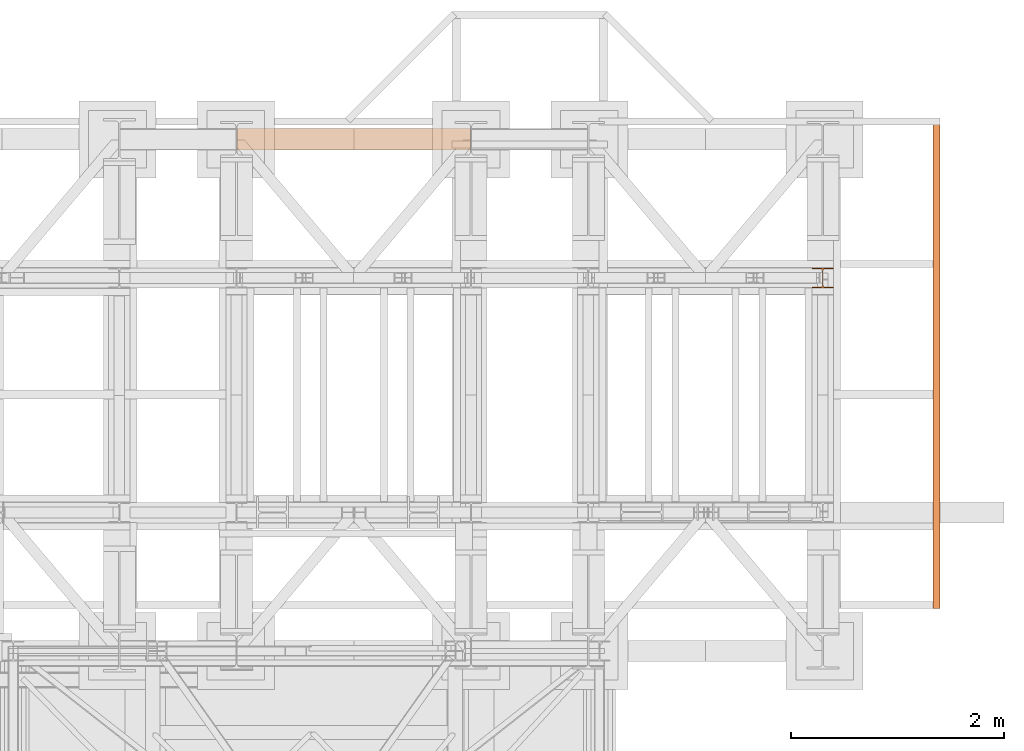
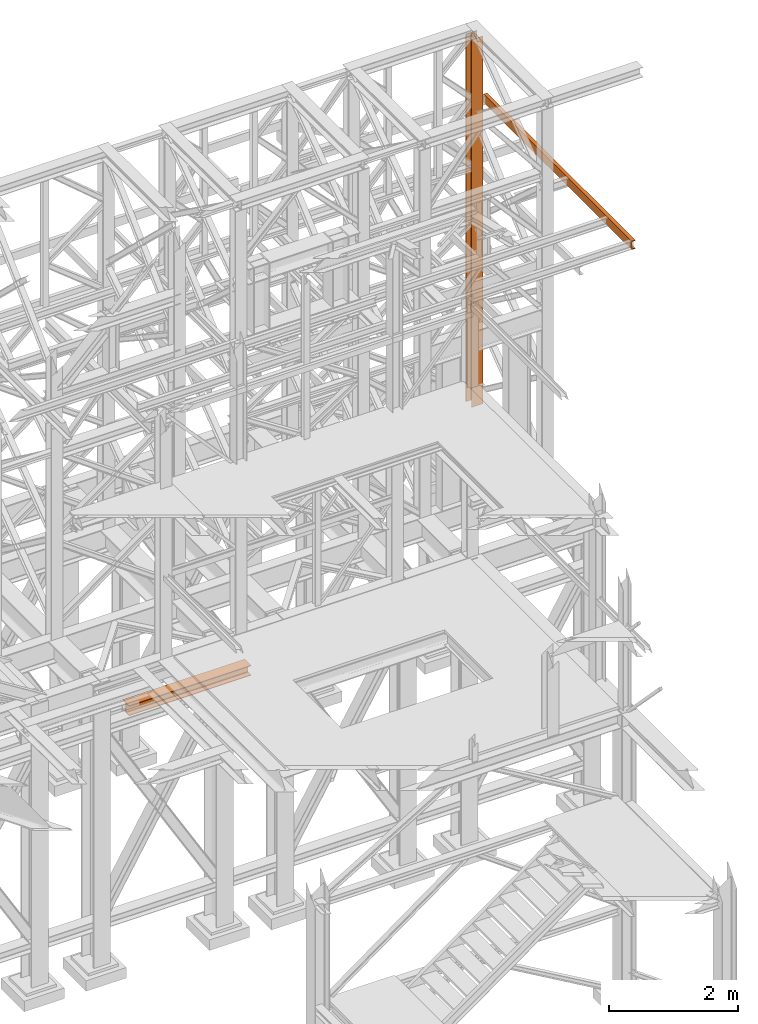
# One storey, part 190 of 208: 3 proxies.
"""IFC2X3 building model written with IfcOpenShell, lengths in millimetres."""

from ifc_helpers import new_model, entity, si_unit, converted_unit, frame, origin, origin_with_axes, place, context, subcontext, project, spatial, faceted_brep, element, save


model = new_model("IFC2X3")

# Units and contexts
model_context = context("Model", 3, precision=1e-05, world=origin())
plan_context = context("Plan", 3, precision=1e-05, world=origin())
body_context = subcontext(model_context, "Body", "Model", "MODEL_VIEW")
ifc_project = project(units=[si_unit("LENGTHUNIT", "METRE", prefix="MILLI"), converted_unit("PLANEANGLEUNIT", "DEGREE", entity("IfcPlaneAngleMeasure", 0.0174532925199433), si_unit("PLANEANGLEUNIT", "RADIAN"), dimensions=[0, 0, 0, 0, 0, 0, 0]), si_unit("AREAUNIT", "SQUARE_METRE"), si_unit("VOLUMEUNIT", "CUBIC_METRE")], contexts=[model_context, plan_context])

# Building, storey
building_placement = place(None, origin())
building = spatial("IfcBuilding", under=ifc_project, at=building_placement, CompositionType="COMPLEX")
storey_placement = place(building_placement, origin_with_axes())
storey = spatial("IfcBuildingStorey", under=building, at=storey_placement, Name="Geschoss", CompositionType="ELEMENT")

# Proxies
proxy_1_placement = place(storey_placement, frame((3299.254968580824, -12562.57439501764, 544.9900024165573), z_axis=(0.0, 0.0, 1.0), x_axis=(1.0, 0.0, 0.0)))
element("IfcBuildingElementProxy", 1, at=proxy_1_placement, inside=storey, context=body_context, shape_type="Brep", body=[
    faceted_brep([(2188.009999895689, 0.01000000000021828, 190.0100125169755), (2188.009999895689, 200.0100029802325, 190.0100125169755), (2188.009999895689, 200.0100029802325, 180.0100146031381), (2188.009999895689, 121.2600035762789, 180.0100071525575), (2188.009999895689, 111.9441915473344, 178.1454621052743), (2188.009999895689, 105.1245498640838, 171.3258190250398), (2188.009999895689, 103.2600015571716, 162.0100079274179), (2188.009999895689, 103.2600015571716, 28.00999713897716), (2188.009999895689, 105.1245498640838, 18.69418604135524), (2188.009999895689, 111.9441915473344, 11.87454296112071), (2188.009999895689, 121.2600035762789, 10.00999791383754), (2188.009999895689, 200.0100029802325, 10.00999791383754), (2188.009999895689, 200.0100029802325, 0.01000000000010459), (2188.009999895689, 0.01000000000021828, 0.01000000000010459), (2188.009999895689, 0.01000000000021828, 10.00999791383754), (2188.009999895689, 78.75999940395377, 10.00999791383754), (2188.009999895689, 88.07581143289826, 11.87454296112071), (2188.009999895689, 94.89545311614893, 18.69418604135524), (2188.009999895689, 96.76000142306111, 28.00999713897716), (2188.009999895689, 96.76000142306111, 162.0100079274179), (2188.009999895689, 94.89545311614893, 171.3258190250398), (2188.009999895689, 88.07581143289826, 178.1454621052743), (2188.009999895689, 78.75999940395377, 180.0100071525575), (2188.009999895689, 0.01000000000021828, 180.0100146031381), (2188.009999895689, 200.0100029802325, 190.0100125169755), (2188.009999895689, 0.01000000000021828, 190.0100125169755), (0.009999999999308784, 0.01000000000203727, 190.0100125169754), (0.009999999999308784, 200.0100029802343, 190.0100125169754), (2188.009999895689, 200.0100029802325, 180.0100146031381), (2188.009999895689, 200.0100029802325, 190.0100125169755), (0.009999999999308784, 200.0100029802343, 190.0100125169754), (0.009999999999308784, 200.0100029802343, 180.010014603138), (2188.009999895689, 121.2600035762789, 180.0100071525575), (2188.009999895689, 200.0100029802325, 180.0100146031381), (0.009999999999308784, 200.0100029802343, 180.010014603138), (0.009999999999308784, 121.2600035762807, 180.0100071525574), (2188.009999895689, 111.9441915473344, 178.1454621052743), (2188.009999895689, 121.2600035762789, 180.0100071525575), (0.009999999999308784, 121.2600035762807, 180.0100071525574), (0.009999999999308784, 111.9441915473362, 178.1454621052742), (2188.009999895689, 105.1245498640838, 171.3258190250398), (2188.009999895689, 111.9441915473344, 178.1454621052743), (0.009999999999308784, 111.9441915473362, 178.1454621052742), (0.009999999999308784, 105.1245498640856, 171.3258190250397), (2188.009999895689, 103.2600015571716, 162.0100079274179), (2188.009999895689, 105.1245498640838, 171.3258190250398), (0.009999999999308784, 105.1245498640856, 171.3258190250397), (0.009999999999308784, 103.2600015571734, 162.0100079274178), (2188.009999895689, 103.2600015571716, 28.00999713897716), (2188.009999895689, 103.2600015571716, 162.0100079274179), (0.009999999999308784, 103.2600015571734, 162.0100079274178), (0.009999999999308784, 103.2600015571734, 28.00999713897704), (2188.009999895689, 105.1245498640838, 18.69418604135524), (2188.009999895689, 103.2600015571716, 28.00999713897716), (0.009999999999308784, 103.2600015571734, 28.00999713897704), (0.009999999999308784, 105.1245498640856, 18.69418604135512), (2188.009999895689, 111.9441915473344, 11.87454296112071), (2188.009999895689, 105.1245498640838, 18.69418604135524), (0.009999999999308784, 105.1245498640856, 18.69418604135512), (0.009999999999308784, 111.9441915473362, 11.8745429611206), (2188.009999895689, 121.2600035762789, 10.00999791383754), (2188.009999895689, 111.9441915473344, 11.87454296112071), (0.009999999999308784, 111.9441915473362, 11.8745429611206), (0.009999999999308784, 121.2600035762807, 10.00999791383742), (2188.009999895689, 200.0100029802325, 10.00999791383754), (2188.009999895689, 121.2600035762789, 10.00999791383754), (0.009999999999308784, 121.2600035762807, 10.00999791383742), (0.009999999999308784, 200.0100029802343, 10.00999791383742), (2188.009999895689, 200.0100029802325, 0.01000000000010459), (2188.009999895689, 200.0100029802325, 10.00999791383754), (0.009999999999308784, 200.0100029802343, 10.00999791383742), (0.009999999999308784, 200.0100029802343, 0.009999999999990905), (2188.009999895689, 0.01000000000021828, 0.01000000000010459), (2188.009999895689, 200.0100029802325, 0.01000000000010459), (0.009999999999308784, 200.0100029802343, 0.009999999999990905), (0.009999999999308784, 0.01000000000203727, 0.009999999999990905), (2188.009999895689, 0.01000000000021828, 10.00999791383754), (2188.009999895689, 0.01000000000021828, 0.01000000000010459), (0.009999999999308784, 0.01000000000203727, 0.009999999999990905), (0.009999999999308784, 0.01000000000203727, 10.00999791383742), (2188.009999895689, 78.75999940395377, 10.00999791383754), (2188.009999895689, 0.01000000000021828, 10.00999791383754), (0.009999999999308784, 0.01000000000203727, 10.00999791383742), (0.009999999999308784, 78.75999940395559, 10.00999791383742), (2188.009999895689, 88.07581143289826, 11.87454296112071), (2188.009999895689, 78.75999940395377, 10.00999791383754), (0.009999999999308784, 78.75999940395559, 10.00999791383742), (0.009999999999308784, 88.07581143290008, 11.8745429611206), (2188.009999895689, 94.89545311614893, 18.69418604135524), (2188.009999895689, 88.07581143289826, 11.87454296112071), (0.009999999999308784, 88.07581143290008, 11.8745429611206), (0.009999999999308784, 94.89545311615075, 18.69418604135512), (2188.009999895689, 96.76000142306111, 28.00999713897716), (2188.009999895689, 94.89545311614893, 18.69418604135524), (0.009999999999308784, 94.89545311615075, 18.69418604135512), (0.009999999999308784, 96.76000142306293, 28.00999713897704), (2188.009999895689, 96.76000142306111, 162.0100079274179), (2188.009999895689, 96.76000142306111, 28.00999713897716), (0.009999999999308784, 96.76000142306293, 28.00999713897704), (0.009999999999308784, 96.76000142306293, 162.0100079274178), (2188.009999895689, 94.89545311614893, 171.3258190250398), (2188.009999895689, 96.76000142306111, 162.0100079274179), (0.009999999999308784, 96.76000142306293, 162.0100079274178), (0.009999999999308784, 94.89545311615075, 171.3258190250397), (2188.009999895689, 88.07581143289826, 178.1454621052743), (2188.009999895689, 94.89545311614893, 171.3258190250398), (0.009999999999308784, 94.89545311615075, 171.3258190250397), (0.009999999999308784, 88.07581143290008, 178.1454621052742), (2188.009999895689, 78.75999940395377, 180.0100071525575), (2188.009999895689, 88.07581143289826, 178.1454621052743), (0.009999999999308784, 88.07581143290008, 178.1454621052742), (0.009999999999308784, 78.75999940395559, 180.0100071525574), (2188.009999895689, 0.01000000000021828, 180.0100146031381), (2188.009999895689, 78.75999940395377, 180.0100071525575), (0.009999999999308784, 78.75999940395559, 180.0100071525574), (0.009999999999308784, 0.01000000000203727, 180.010014603138), (2188.009999895689, 0.01000000000021828, 190.0100125169755), (2188.009999895689, 0.01000000000021828, 180.0100146031381), (0.009999999999308784, 0.01000000000203727, 180.010014603138), (0.009999999999308784, 0.01000000000203727, 190.0100125169754), (0.009999999999308784, 0.01000000000203727, 190.0100125169754), (0.009999999999308784, 0.01000000000203727, 180.010014603138), (0.009999999999308784, 78.75999940395559, 180.0100071525574), (0.009999999999308784, 88.07581143290008, 178.1454621052742), (0.009999999999308784, 94.89545311615075, 171.3258190250397), (0.009999999999308784, 96.76000142306293, 162.0100079274178), (0.009999999999308784, 96.76000142306293, 28.00999713897704), (0.009999999999308784, 94.89545311615075, 18.69418604135512), (0.009999999999308784, 88.07581143290008, 11.8745429611206), (0.009999999999308784, 78.75999940395559, 10.00999791383742), (0.009999999999308784, 0.01000000000203727, 10.00999791383742), (0.009999999999308784, 0.01000000000203727, 0.009999999999990905), (0.009999999999308784, 200.0100029802343, 0.009999999999990905), (0.009999999999308784, 200.0100029802343, 10.00999791383742), (0.009999999999308784, 121.2600035762807, 10.00999791383742), (0.009999999999308784, 111.9441915473362, 11.8745429611206), (0.009999999999308784, 105.1245498640856, 18.69418604135512), (0.009999999999308784, 103.2600015571734, 28.00999713897704), (0.009999999999308784, 103.2600015571734, 162.0100079274178), (0.009999999999308784, 105.1245498640856, 171.3258190250397), (0.009999999999308784, 111.9441915473362, 178.1454621052742), (0.009999999999308784, 121.2600035762807, 180.0100071525574), (0.009999999999308784, 200.0100029802343, 180.010014603138), (0.009999999999308784, 200.0100029802343, 190.0100125169754)], [[[0, 1, 2, 3, 4, 5, 6, 7, 8, 9, 10, 11, 12, 13, 14, 15, 16, 17, 18, 19, 20, 21, 22, 23]], [[24, 25, 26, 27]], [[28, 29, 30, 31]], [[32, 33, 34, 35]], [[36, 37, 38, 39]], [[40, 41, 42, 43]], [[44, 45, 46, 47]], [[48, 49, 50, 51]], [[52, 53, 54, 55]], [[56, 57, 58, 59]], [[60, 61, 62, 63]], [[64, 65, 66, 67]], [[68, 69, 70, 71]], [[72, 73, 74, 75]], [[76, 77, 78, 79]], [[80, 81, 82, 83]], [[84, 85, 86, 87]], [[88, 89, 90, 91]], [[92, 93, 94, 95]], [[96, 97, 98, 99]], [[100, 101, 102, 103]], [[104, 105, 106, 107]], [[108, 109, 110, 111]], [[112, 113, 114, 115]], [[116, 117, 118, 119]], [[120, 121, 122, 123, 124, 125, 126, 127, 128, 129, 130, 131, 132, 133, 134, 135, 136, 137, 138, 139, 140, 141, 142, 143]]], orient=[[False], [False], [False], [False], [False], [False], [False], [False], [False], [False], [False], [False], [False], [False], [False], [False], [False], [False], [False], [False], [False], [False], [False], [False], [False], [False]]),
])
proxy_2_placement = place(storey_placement, frame((8693.25496703855, -13857.57439657638, 5284.990005364415), z_axis=(0.0, 0.0, 1.0), x_axis=(1.0, 0.0, 0.0)))
element("IfcBuildingElementProxy", 2, at=proxy_2_placement, inside=storey, context=body_context, shape_type="Brep", body=[
    faceted_brep([(0.01000000000021828, 190.0100125169756, 6965.010053329393), (200.0100029802325, 190.0100125169756, 6965.010053329393), (200.0100029802325, 180.0100146031382, 6965.010053329393), (121.2600035762789, 180.0100071525576, 6965.010053329393), (111.9441915473344, 178.1454621052744, 6965.010053329393), (105.1245498640838, 171.3258190250399, 6965.010053329393), (103.2600015571716, 162.010007927418, 6965.010053329393), (103.2600015571716, 28.00999713897727, 6965.010053329393), (105.1245498640838, 18.69418604135535, 6965.010053329393), (111.9441915473344, 11.87454296112082, 6965.010053329393), (121.2600035762789, 10.00999791383765, 6965.010053329393), (200.0100029802325, 10.00999791383765, 6965.010053329393), (200.0100029802325, 0.01000000000021828, 6965.010053329393), (0.01000000000021828, 0.01000000000021828, 6965.010053329393), (0.01000000000021828, 10.00999791383765, 6965.010053329393), (78.75999940395377, 10.00999791383765, 6965.010053329393), (88.07581143289826, 11.87454296112082, 6965.010053329393), (94.89545311614893, 18.69418604135535, 6965.010053329393), (96.76000142306111, 28.00999713897727, 6965.010053329393), (96.76000142306111, 162.010007927418, 6965.010053329393), (94.89545311614893, 171.3258190250399, 6965.010053329393), (88.07581143289826, 178.1454621052744, 6965.010053329393), (78.75999940395377, 180.0100071525576, 6965.010053329393), (0.01000000000021828, 180.0100146031382, 6965.010053329393), (200.0100029802325, 190.0100125169756, 6965.010053329393), (0.01000000000021828, 190.0100125169756, 6965.010053329393), (0.01000000000021828, 190.0100125169756, 0.01000000000112777), (200.0100029802325, 190.0100125169756, 0.01000000000112777), (200.0100029802325, 180.0100146031382, 6965.010053329393), (200.0100029802325, 190.0100125169756, 6965.010053329393), (200.0100029802325, 190.0100125169756, 0.01000000000112777), (200.0100029802325, 180.0100146031382, 0.01000000000112777), (121.2600035762789, 180.0100071525576, 6965.010053329393), (200.0100029802325, 180.0100146031382, 6965.010053329393), (200.0100029802325, 180.0100146031382, 0.01000000000112777), (121.2600035762789, 180.0100071525576, 0.01000000000112777), (111.9441915473344, 178.1454621052744, 6965.010053329393), (121.2600035762789, 180.0100071525576, 6965.010053329393), (121.2600035762789, 180.0100071525576, 0.01000000000112777), (111.9441915473344, 178.1454621052744, 0.01000000000112777), (105.1245498640838, 171.3258190250399, 6965.010053329393), (111.9441915473344, 178.1454621052744, 6965.010053329393), (111.9441915473344, 178.1454621052744, 0.01000000000112777), (105.1245498640838, 171.3258190250399, 0.01000000000112777), (103.2600015571716, 162.010007927418, 6965.010053329393), (105.1245498640838, 171.3258190250399, 6965.010053329393), (105.1245498640838, 171.3258190250399, 0.01000000000112777), (103.2600015571716, 162.010007927418, 0.01000000000112777), (103.2600015571716, 28.00999713897727, 6965.010053329393), (103.2600015571716, 162.010007927418, 6965.010053329393), (103.2600015571716, 162.010007927418, 0.01000000000112777), (103.2600015571716, 28.00999713897727, 0.01000000000112777), (105.1245498640838, 18.69418604135535, 6965.010053329393), (103.2600015571716, 28.00999713897727, 6965.010053329393), (103.2600015571716, 28.00999713897727, 0.01000000000112777), (105.1245498640838, 18.69418604135535, 0.01000000000112777), (111.9441915473344, 11.87454296112082, 6965.010053329393), (105.1245498640838, 18.69418604135535, 6965.010053329393), (105.1245498640838, 18.69418604135535, 0.01000000000112777), (111.9441915473344, 11.87454296112082, 0.01000000000112777), (121.2600035762789, 10.00999791383765, 6965.010053329393), (111.9441915473344, 11.87454296112082, 6965.010053329393), (111.9441915473344, 11.87454296112082, 0.01000000000112777), (121.2600035762789, 10.00999791383765, 0.01000000000112777), (200.0100029802325, 10.00999791383765, 6965.010053329393), (121.2600035762789, 10.00999791383765, 6965.010053329393), (121.2600035762789, 10.00999791383765, 0.01000000000112777), (200.0100029802325, 10.00999791383765, 0.01000000000112777), (200.0100029802325, 0.01000000000021828, 6965.010053329393), (200.0100029802325, 10.00999791383765, 6965.010053329393), (200.0100029802325, 10.00999791383765, 0.01000000000112777), (200.0100029802325, 0.01000000000021828, 0.01000000000112777), (0.01000000000021828, 0.01000000000021828, 6965.010053329393), (200.0100029802325, 0.01000000000021828, 6965.010053329393), (200.0100029802325, 0.01000000000021828, 0.01000000000112777), (0.01000000000021828, 0.01000000000021828, 0.01000000000112777), (0.01000000000021828, 10.00999791383765, 6965.010053329393), (0.01000000000021828, 0.01000000000021828, 6965.010053329393), (0.01000000000021828, 0.01000000000021828, 0.01000000000112777), (0.01000000000021828, 10.00999791383765, 0.01000000000112777), (78.75999940395377, 10.00999791383765, 6965.010053329393), (0.01000000000021828, 10.00999791383765, 6965.010053329393), (0.01000000000021828, 10.00999791383765, 0.01000000000112777), (78.75999940395377, 10.00999791383765, 0.01000000000112777), (88.07581143289826, 11.87454296112082, 6965.010053329393), (78.75999940395377, 10.00999791383765, 6965.010053329393), (78.75999940395377, 10.00999791383765, 0.01000000000112777), (88.07581143289826, 11.87454296112082, 0.01000000000112777), (94.89545311614893, 18.69418604135535, 6965.010053329393), (88.07581143289826, 11.87454296112082, 6965.010053329393), (88.07581143289826, 11.87454296112082, 0.01000000000112777), (94.89545311614893, 18.69418604135535, 0.01000000000112777), (96.76000142306111, 28.00999713897727, 6965.010053329393), (94.89545311614893, 18.69418604135535, 6965.010053329393), (94.89545311614893, 18.69418604135535, 0.01000000000112777), (96.76000142306111, 28.00999713897727, 0.01000000000112777), (96.76000142306111, 162.010007927418, 6965.010053329393), (96.76000142306111, 28.00999713897727, 6965.010053329393), (96.76000142306111, 28.00999713897727, 0.01000000000112777), (96.76000142306111, 162.010007927418, 0.01000000000112777), (94.89545311614893, 171.3258190250399, 6965.010053329393), (96.76000142306111, 162.010007927418, 6965.010053329393), (96.76000142306111, 162.010007927418, 0.01000000000112777), (94.89545311614893, 171.3258190250399, 0.01000000000112777), (88.07581143289826, 178.1454621052744, 6965.010053329393), (94.89545311614893, 171.3258190250399, 6965.010053329393), (94.89545311614893, 171.3258190250399, 0.01000000000112777), (88.07581143289826, 178.1454621052744, 0.01000000000112777), (78.75999940395377, 180.0100071525576, 6965.010053329393), (88.07581143289826, 178.1454621052744, 6965.010053329393), (88.07581143289826, 178.1454621052744, 0.01000000000112777), (78.75999940395377, 180.0100071525576, 0.01000000000112777), (0.01000000000021828, 180.0100146031382, 6965.010053329393), (78.75999940395377, 180.0100071525576, 6965.010053329393), (78.75999940395377, 180.0100071525576, 0.01000000000112777), (0.01000000000021828, 180.0100146031382, 0.01000000000112777), (0.01000000000021828, 190.0100125169756, 6965.010053329393), (0.01000000000021828, 180.0100146031382, 6965.010053329393), (0.01000000000021828, 180.0100146031382, 0.01000000000112777), (0.01000000000021828, 190.0100125169756, 0.01000000000112777), (0.01000000000021828, 190.0100125169756, 0.01000000000112777), (0.01000000000021828, 180.0100146031382, 0.01000000000112777), (78.75999940395377, 180.0100071525576, 0.01000000000112777), (88.07581143289826, 178.1454621052744, 0.01000000000112777), (94.89545311614893, 171.3258190250399, 0.01000000000112777), (96.76000142306111, 162.010007927418, 0.01000000000112777), (96.76000142306111, 28.00999713897727, 0.01000000000112777), (94.89545311614893, 18.69418604135535, 0.01000000000112777), (88.07581143289826, 11.87454296112082, 0.01000000000112777), (78.75999940395377, 10.00999791383765, 0.01000000000112777), (0.01000000000021828, 10.00999791383765, 0.01000000000112777), (0.01000000000021828, 0.01000000000021828, 0.01000000000112777), (200.0100029802325, 0.01000000000021828, 0.01000000000112777), (200.0100029802325, 10.00999791383765, 0.01000000000112777), (121.2600035762789, 10.00999791383765, 0.01000000000112777), (111.9441915473344, 11.87454296112082, 0.01000000000112777), (105.1245498640838, 18.69418604135535, 0.01000000000112777), (103.2600015571716, 28.00999713897727, 0.01000000000112777), (103.2600015571716, 162.010007927418, 0.01000000000112777), (105.1245498640838, 171.3258190250399, 0.01000000000112777), (111.9441915473344, 178.1454621052744, 0.01000000000112777), (121.2600035762789, 180.0100071525576, 0.01000000000112777), (200.0100029802325, 180.0100146031382, 0.01000000000112777), (200.0100029802325, 190.0100125169756, 0.01000000000112777)], [[[0, 1, 2, 3, 4, 5, 6, 7, 8, 9, 10, 11, 12, 13, 14, 15, 16, 17, 18, 19, 20, 21, 22, 23]], [[24, 25, 26, 27]], [[28, 29, 30, 31]], [[32, 33, 34, 35]], [[36, 37, 38, 39]], [[40, 41, 42, 43]], [[44, 45, 46, 47]], [[48, 49, 50, 51]], [[52, 53, 54, 55]], [[56, 57, 58, 59]], [[60, 61, 62, 63]], [[64, 65, 66, 67]], [[68, 69, 70, 71]], [[72, 73, 74, 75]], [[76, 77, 78, 79]], [[80, 81, 82, 83]], [[84, 85, 86, 87]], [[88, 89, 90, 91]], [[92, 93, 94, 95]], [[96, 97, 98, 99]], [[100, 101, 102, 103]], [[104, 105, 106, 107]], [[108, 109, 110, 111]], [[112, 113, 114, 115]], [[116, 117, 118, 119]], [[120, 121, 122, 123, 124, 125, 126, 127, 128, 129, 130, 131, 132, 133, 134, 135, 136, 137, 138, 139, 140, 141, 142, 143]]], orient=[[False], [False], [False], [False], [False], [False], [False], [False], [False], [False], [False], [False], [False], [False], [False], [False], [False], [False], [False], [False], [False], [False], [False], [False], [False], [False]]),
])
proxy_3_placement = place(storey_placement, frame((9828.01223344161, -16862.574391808, 9699.99), z_axis=(0.0, 0.0, 1.0), x_axis=(1.0, 0.0, 0.0)))
element("IfcBuildingElementProxy", 3, at=proxy_3_placement, inside=storey, context=body_context, shape_type="Brep", body=[
    faceted_brep([(65.01000000000022, 4600.010002980231, 0.01000000000021828), (65.01000000000022, 0.00999999999839929, 0.01000000000021828), (65.01000000000022, 0.00999999999839929, 3.132428070246533), (65.01000000000022, 4600.010002980231, 3.132428070246533), (65.01000000000022, 4600.010002980231, 3.132428070246533), (65.01000000000022, 0.00999999999839929, 3.132428070246533), (64.76726342282745, 0.00999999999839929, 4.748288908171162), (64.76726342282745, 4600.010002980231, 4.748288908171162), (64.76726342282745, 4600.010002980231, 4.748288908171162), (64.76726342282745, 0.00999999999839929, 4.748288908171162), (64.06053228585733, 0.00999999999839929, 6.221534443444398), (64.06053228585733, 4600.010002980231, 6.221534443444398), (64.06053228585733, 4600.010002980231, 6.221534443444398), (64.06053228585733, 0.00999999999839929, 6.221534443444398), (62.95215163846842, 0.00999999999839929, 7.422126703873801), (62.95215163847024, 4600.010002980231, 7.422126703873801), (62.95215163847024, 4600.010002980231, 7.422126703873801), (62.95215163846842, 0.00999999999839929, 7.422126703873801), (61.53995641148504, 0.00999999999839929, 8.244091391710754), (61.53995641148504, 4600.010002980231, 8.244091391710754), (61.53995641148504, 4600.010002980231, 8.244091391710754), (61.53995641148504, 0.00999999999839929, 8.244091391710754), (59.9485987225562, 0.00999999999839929, 8.614912102195376), (59.9485987225562, 4600.010002980231, 8.614912102195376), (59.9485987225562, 4600.010002980231, 8.614912102195376), (59.9485987225562, 0.00999999999839929, 8.614912102195376), (17.17267516602988, 0.00999999999839929, 12.0369859867169), (17.17267516602988, 4600.010002980231, 12.0369859867169), (17.17267516602988, 4600.010002980231, 12.0369859867169), (17.17267516602988, 0.00999999999839929, 12.0369859867169), (14.13462866898408, 0.00999999999839929, 12.74491643400506), (14.13462866898408, 4600.010002980231, 12.74491643400506), (14.13462866898408, 4600.010002980231, 12.74491643400506), (14.13462866898408, 0.00999999999839929, 12.74491643400506), (11.43861959928654, 0.00999999999839929, 14.31412174714933), (11.43861959928836, 4600.010002980231, 14.31412174714933), (11.43861959928836, 4600.010002980231, 14.31412174714933), (11.43861959928654, 0.00999999999839929, 14.31412174714933), (9.322620181546881, 0.00999999999839929, 16.60616151705835), (9.3226201815487, 4600.010002980231, 16.60616151705835), (9.3226201815487, 4600.010002980231, 16.60616151705835), (9.322620181546881, 0.00999999999839929, 16.60616151705835), (7.97340619278657, 0.00999999999839929, 19.41872117530875), (7.97340619278657, 4600.010002980231, 19.41872117530875), (7.97340619278657, 4600.010002980231, 19.41872117530875), (7.97340619278657, 0.00999999999839929, 19.41872117530875), (7.510000000000218, 0.00999999999839929, 22.50354641134618), (7.510000000000218, 4600.010002980231, 22.50354641134618), (7.510000000000218, 4600.010002980231, 22.50354641134618), (7.510000000000218, 0.00999999999839929, 22.50354641134618), (7.510000000000218, 0.00999999999839929, 137.5164535886524), (7.510000000000218, 4600.010002980231, 137.5164535886524), (7.510000000000218, 4600.010002980231, 137.5164535886524), (7.510000000000218, 0.00999999999839929, 137.5164535886524), (7.97340619278657, 0.00999999999839929, 140.6012788246917), (7.97340619278657, 4600.010002980231, 140.6012788246917), (7.97340619278657, 4600.010002980231, 140.6012788246917), (7.97340619278657, 0.00999999999839929, 140.6012788246917), (9.322620181546881, 0.00999999999839929, 143.4138384829403), (9.3226201815487, 4600.010002980231, 143.4138384829403), (9.3226201815487, 4600.010002980231, 143.4138384829403), (9.322620181546881, 0.00999999999839929, 143.4138384829403), (11.43861959928654, 0.00999999999839929, 145.7058782528493), (11.43861959928836, 4600.010002980231, 145.7058782528493), (11.43861959928836, 4600.010002980231, 145.7058782528493), (11.43861959928654, 0.00999999999839929, 145.7058782528493), (14.13462866898408, 0.00999999999839929, 147.2750835659936), (14.13462866898408, 4600.010002980231, 147.2750835659936), (14.13462866898408, 4600.010002980231, 147.2750835659936), (14.13462866898408, 0.00999999999839929, 147.2750835659936), (17.17267516602988, 0.00999999999839929, 147.9830140132817), (17.17267516602988, 4600.010002980231, 147.9830140132817), (17.17267516602988, 4600.010002980231, 147.9830140132817), (17.17267516602988, 0.00999999999839929, 147.9830140132817), (59.9485987225562, 0.00999999999839929, 151.4050878978032), (59.9485987225562, 4600.010002980231, 151.4050878978032), (59.9485987225562, 4600.010002980231, 151.4050878978032), (59.9485987225562, 0.00999999999839929, 151.4050878978032), (61.53995641148504, 0.00999999999839929, 151.7759086082879), (61.53995641148504, 4600.010002980231, 151.7759086082879), (61.53995641148504, 4600.010002980231, 151.7759086082879), (61.53995641148504, 0.00999999999839929, 151.7759086082879), (62.95215163846842, 0.00999999999839929, 152.5978732961248), (62.95215163847024, 4600.010002980231, 152.5978732961248), (62.95215163847024, 4600.010002980231, 152.5978732961248), (62.95215163846842, 0.00999999999839929, 152.5978732961248), (64.06053228585733, 0.00999999999839929, 153.7984655565542), (64.06053228585733, 4600.010002980231, 153.7984655565542), (64.06053228585733, 4600.010002980231, 153.7984655565542), (64.06053228585733, 0.00999999999839929, 153.7984655565542), (64.76726342282745, 0.00999999999839929, 155.2717110918275), (64.76726342282745, 4600.010002980231, 155.2717110918275), (64.76726342282745, 4600.010002980231, 155.2717110918275), (64.76726342282745, 0.00999999999839929, 155.2717110918275), (65.01000000000022, 0.00999999999839929, 156.8875719297521), (65.01000000000022, 4600.010002980231, 156.8875719297521), (65.01000000000022, 4600.010002980231, 156.8875719297521), (65.01000000000022, 0.00999999999839929, 156.8875719297521), (65.01000000000022, 0.00999999999839929, 160.0100000000002), (65.01000000000022, 4600.010002980231, 160.0100000000002), (65.01000000000022, 4600.010002980231, 160.0100000000002), (65.01000000000022, 0.00999999999839929, 160.0100000000002), (0.01000000000021828, 0.00999999999839929, 160.0100000000002), (0.01000000000021828, 4600.010002980231, 160.0100000000002), (0.01000000000021828, 4600.010002980231, 160.0100000000002), (0.01000000000021828, 0.00999999999839929, 160.0100000000002), (0.01000000000021828, 0.00999999999839929, 0.01000000000021828), (0.01000000000021828, 4600.010002980231, 0.01000000000021828), (0.01000000000021828, 4600.010002980231, 0.01000000000021828), (0.01000000000021828, 0.00999999999839929, 0.01000000000021828), (65.01000000000022, 0.00999999999839929, 0.01000000000021828), (65.01000000000022, 4600.010002980231, 0.01000000000021828), (65.01000000000022, 4600.010002980231, 0.01000000000021828), (65.01000000000022, 4600.010002980231, 3.132428070246533), (64.76726342282745, 4600.010002980231, 4.748288908171162), (64.06053228585733, 4600.010002980231, 6.221534443444398), (62.95215163847024, 4600.010002980231, 7.422126703873801), (61.53995641148504, 4600.010002980231, 8.244091391710754), (59.9485987225562, 4600.010002980231, 8.614912102195376), (17.17267516602988, 4600.010002980231, 12.0369859867169), (14.13462866898408, 4600.010002980231, 12.74491643400506), (11.43861959928836, 4600.010002980231, 14.31412174714933), (9.3226201815487, 4600.010002980231, 16.60616151705835), (7.97340619278657, 4600.010002980231, 19.41872117530875), (7.510000000000218, 4600.010002980231, 22.50354641134618), (7.510000000000218, 4600.010002980231, 137.5164535886524), (7.97340619278657, 4600.010002980231, 140.6012788246917), (9.3226201815487, 4600.010002980231, 143.4138384829403), (11.43861959928836, 4600.010002980231, 145.7058782528493), (14.13462866898408, 4600.010002980231, 147.2750835659936), (17.17267516602988, 4600.010002980231, 147.9830140132817), (59.9485987225562, 4600.010002980231, 151.4050878978032), (61.53995641148504, 4600.010002980231, 151.7759086082879), (62.95215163847024, 4600.010002980231, 152.5978732961248), (64.06053228585733, 4600.010002980231, 153.7984655565542), (64.76726342282745, 4600.010002980231, 155.2717110918275), (65.01000000000022, 4600.010002980231, 156.8875719297521), (65.01000000000022, 4600.010002980231, 160.0100000000002), (0.01000000000021828, 4600.010002980231, 160.0100000000002), (0.01000000000021828, 4600.010002980231, 0.01000000000021828), (65.01000000000022, 0.00999999999839929, 0.01000000000021828), (0.01000000000021828, 0.00999999999839929, 0.01000000000021828), (0.01000000000021828, 0.00999999999839929, 160.0100000000002), (65.01000000000022, 0.00999999999839929, 160.0100000000002), (65.01000000000022, 0.00999999999839929, 156.8875719297521), (64.76726342282745, 0.00999999999839929, 155.2717110918275), (64.06053228585733, 0.00999999999839929, 153.7984655565542), (62.95215163846842, 0.00999999999839929, 152.5978732961248), (61.53995641148504, 0.00999999999839929, 151.7759086082879), (59.9485987225562, 0.00999999999839929, 151.4050878978032), (17.17267516602988, 0.00999999999839929, 147.9830140132817), (14.13462866898408, 0.00999999999839929, 147.2750835659936), (11.43861959928654, 0.00999999999839929, 145.7058782528493), (9.322620181546881, 0.00999999999839929, 143.4138384829403), (7.97340619278657, 0.00999999999839929, 140.6012788246917), (7.510000000000218, 0.00999999999839929, 137.5164535886524), (7.510000000000218, 0.00999999999839929, 22.50354641134618), (7.97340619278657, 0.00999999999839929, 19.41872117530875), (9.322620181546881, 0.00999999999839929, 16.60616151705835), (11.43861959928654, 0.00999999999839929, 14.31412174714933), (14.13462866898408, 0.00999999999839929, 12.74491643400506), (17.17267516602988, 0.00999999999839929, 12.0369859867169), (59.9485987225562, 0.00999999999839929, 8.614912102195376), (61.53995641148504, 0.00999999999839929, 8.244091391710754), (62.95215163846842, 0.00999999999839929, 7.422126703873801), (64.06053228585733, 0.00999999999839929, 6.221534443444398), (64.76726342282745, 0.00999999999839929, 4.748288908171162), (65.01000000000022, 0.00999999999839929, 3.132428070246533)], [[[0, 1, 2, 3]], [[4, 5, 6, 7]], [[8, 9, 10, 11]], [[12, 13, 14, 15]], [[16, 17, 18, 19]], [[20, 21, 22, 23]], [[24, 25, 26, 27]], [[28, 29, 30, 31]], [[32, 33, 34, 35]], [[36, 37, 38, 39]], [[40, 41, 42, 43]], [[44, 45, 46, 47]], [[48, 49, 50, 51]], [[52, 53, 54, 55]], [[56, 57, 58, 59]], [[60, 61, 62, 63]], [[64, 65, 66, 67]], [[68, 69, 70, 71]], [[72, 73, 74, 75]], [[76, 77, 78, 79]], [[80, 81, 82, 83]], [[84, 85, 86, 87]], [[88, 89, 90, 91]], [[92, 93, 94, 95]], [[96, 97, 98, 99]], [[100, 101, 102, 103]], [[104, 105, 106, 107]], [[108, 109, 110, 111]], [[112, 113, 114, 115, 116, 117, 118, 119, 120, 121, 122, 123, 124, 125, 126, 127, 128, 129, 130, 131, 132, 133, 134, 135, 136, 137, 138, 139]], [[140, 141, 142, 143, 144, 145, 146, 147, 148, 149, 150, 151, 152, 153, 154, 155, 156, 157, 158, 159, 160, 161, 162, 163, 164, 165, 166, 167]]], orient=[[False], [False], [False], [False], [False], [False], [False], [False], [False], [False], [False], [False], [False], [False], [False], [False], [False], [False], [False], [False], [False], [False], [False], [False], [False], [False], [False], [False], [False], [False]]),
])

save(model, "model.ifc")
